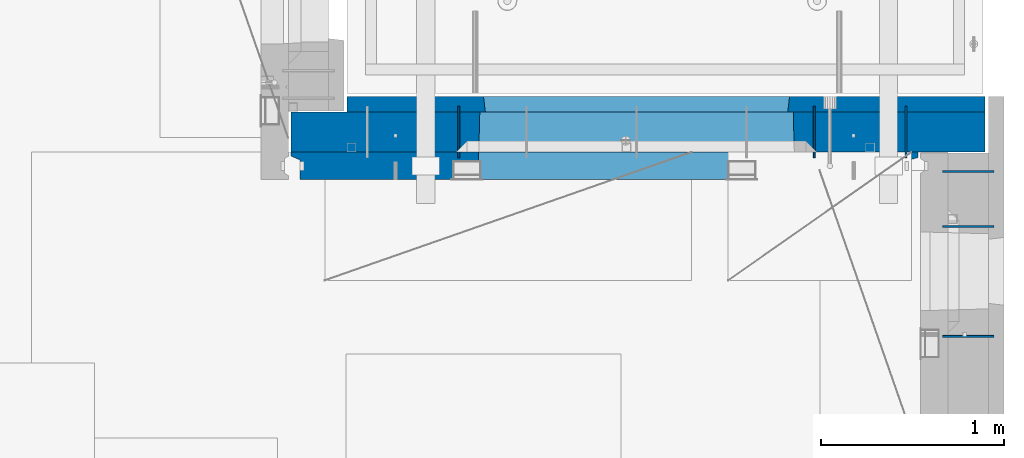
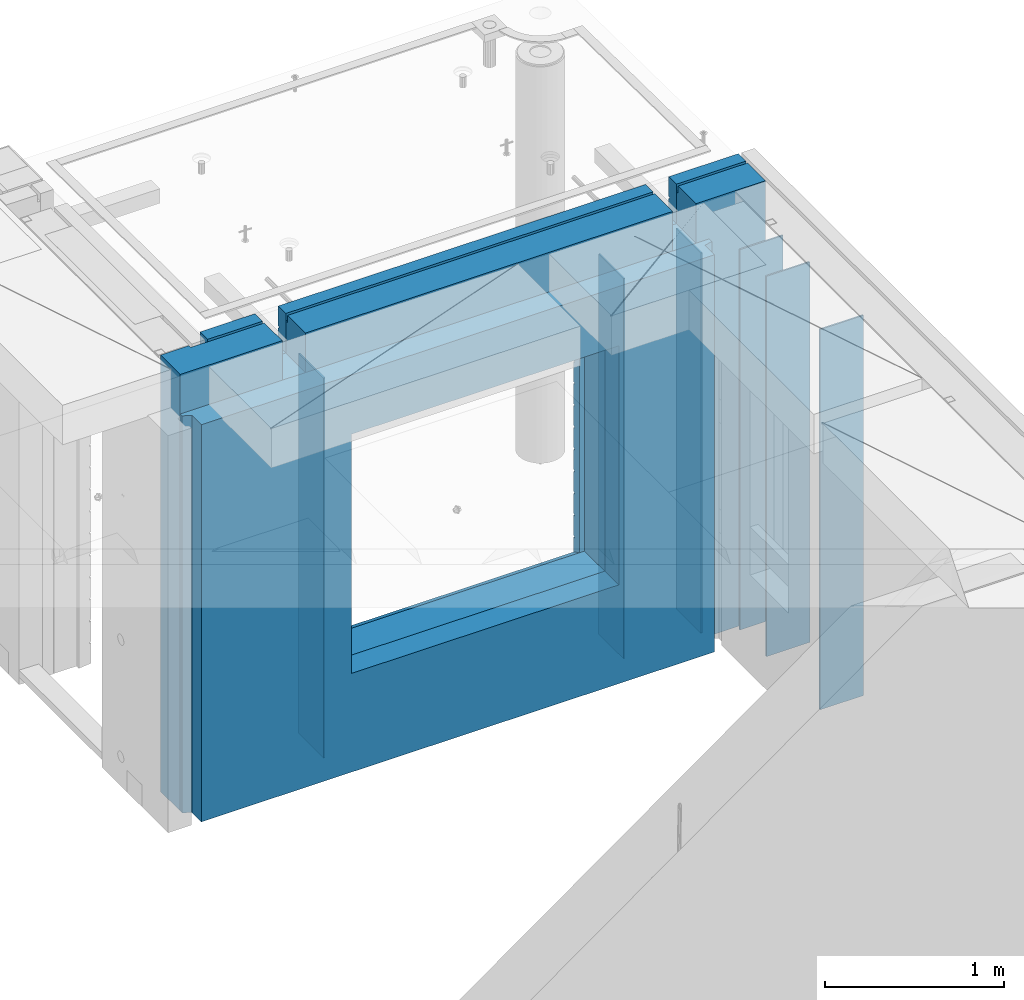
# One storey, part 231 of 334: 9 walls, 2 elements without a shape of their own.
"""IFC2X3 building model written with IfcOpenShell, lengths in millimetres."""

import ifcopenshell
import ifcopenshell.guid

model = None  # the IFC model being written
_history = None  # IfcOwnerHistory: only IFC2X3 demands one
_inside = {}  # id of a spatial element -> (the spatial element, [elements in it])
_under = {}  # id of a project, library or spatial element -> (it, [spatial elements below it])
_declared = {}  # id of a project -> (the project, [libraries it declares])
_typed = {}  # id of a type object -> (the type object, [elements of that type])
_made_of = {}  # id of a material, layer set ... -> (it, [elements and type objects made of it])


def new_model(schema):
    """Start an empty IFC model of exactly this schema.

    Asked for "IFC4X3", IfcOpenShell would pick the latest addendum, in which some entities
    have other attributes; the version numbers below select the first issue.
    IFC2X3 requires an IfcOwnerHistory on every rooted entity: one is made here for all.
    """
    global model, _history
    if schema == "IFC4X3":
        model = ifcopenshell.file(schema_version=(4, 3, 0, 0))
    else:
        model = ifcopenshell.file(schema=schema)
    _inside.clear()
    _under.clear()
    _declared.clear()
    _typed.clear()
    _made_of.clear()
    _history = None
    if model.schema == "IFC2X3":
        org = make("IfcOrganization", Name="unknown")
        user = make(
            "IfcPersonAndOrganization",
            ThePerson=make("IfcPerson", FamilyName="unknown"),
            TheOrganization=org,
        )
        app = make(
            "IfcApplication",
            ApplicationDeveloper=org,
            Version="unknown",
            ApplicationFullName="unknown",
            ApplicationIdentifier="unknown",
        )
        _history = make(
            "IfcOwnerHistory",
            OwningUser=user,
            OwningApplication=app,
            ChangeAction="ADDED",
            CreationDate=0,
        )
    return model


def make(cls, **values):
    """One entity of the class cls with the attributes given. An attribute that is None is left unset."""
    return model.create_entity(
        cls, **{name: value for name, value in values.items() if value is not None}
    )


def rooted(cls, **values):
    """An entity with a GlobalId (a new one), such as an element, a storey or a relation."""
    return make(cls, GlobalId=ifcopenshell.guid.new(), OwnerHistory=_history, **values)


def si_unit(unit_type, name, prefix=None):
    """IfcSIUnit, for example si_unit("LENGTHUNIT", "METRE", prefix="MILLI")."""
    return make("IfcSIUnit", UnitType=unit_type, Prefix=prefix, Name=name)


def assignment(units):
    """IfcUnitAssignment: the units of a project."""
    return None if units is None else make("IfcUnitAssignment", Units=units)


def point(xyz):
    """IfcCartesianPoint."""
    return None if xyz is None else make("IfcCartesianPoint", Coordinates=xyz)


def direction(xyz):
    """IfcDirection."""
    return None if xyz is None else make("IfcDirection", DirectionRatios=xyz)


def frame(location, z_axis=None, x_axis=None):
    """IfcAxis2Placement3D, a coordinate frame: its origin and axes. An axis left out is left unset."""
    return make(
        "IfcAxis2Placement3D",
        Location=point(location),
        Axis=direction(z_axis),
        RefDirection=direction(x_axis),
    )


def origin_with_axes():
    """The frame at (0, 0, 0) with the z axis (0, 0, 1) and the x axis (1, 0, 0) written out."""
    return frame((0.0, 0.0, 0.0), z_axis=(0.0, 0.0, 1.0), x_axis=(1.0, 0.0, 0.0))


def place(relative_to, where):
    """IfcLocalPlacement: puts the frame where relative to a parent placement (None: the world)."""
    return make(
        "IfcLocalPlacement", PlacementRelTo=relative_to, RelativePlacement=where
    )


def context(
    kind, dimensions, precision=None, world=None, true_north=None, identifier=None
):
    """IfcGeometricRepresentationContext, for example the 3D "Model" context."""
    return make(
        "IfcGeometricRepresentationContext",
        ContextIdentifier=identifier,
        ContextType=kind,
        CoordinateSpaceDimension=dimensions,
        Precision=precision,
        WorldCoordinateSystem=world,
        TrueNorth=true_north,
    )


def subcontext(parent, identifier, kind, view, scale=None):
    """IfcGeometricRepresentationSubContext, for example "Body" below "Model"."""
    return make(
        "IfcGeometricRepresentationSubContext",
        ContextIdentifier=identifier,
        ContextType=kind,
        ParentContext=parent,
        TargetScale=scale,
        TargetView=view,
    )


def project(units=None, contexts=None):
    """IfcProject with its units and contexts."""
    return rooted(
        "IfcProject",
        Name="project",
        RepresentationContexts=contexts,
        UnitsInContext=assignment(units),
    )


def spatial(cls, under=None, at=None, **own):
    """A site, building, storey or space (cls), placed at a placement, below another one or the project."""
    s = rooted(cls, ObjectPlacement=at, **own)
    if under is not None:
        _under.setdefault(under.id(), (under, []))[1].append(s)
    return s


def faces_of(points, faces, orient=None, outer=None):
    """IfcFace entities. A face is a list of loops; a loop is a list of indices into points, from 0.

    orient and outer hold one flag for each loop. By default every Orientation is true, the
    first loop of a face is its IfcFaceOuterBound and the others are IfcFaceBound.
    """
    made = []
    for i, loops in enumerate(faces):
        bounds = []
        for j, loop in enumerate(loops):
            is_outer = j == 0 if outer is None else outer[i][j]
            bounds.append(
                make(
                    "IfcFaceOuterBound" if is_outer else "IfcFaceBound",
                    Bound=make("IfcPolyLoop", Polygon=[points[k] for k in loop]),
                    Orientation=True if orient is None else orient[i][j],
                )
            )
        made.append(make("IfcFace", Bounds=bounds))
    return made


def faceted_brep(points, faces, orient=None, outer=None, voids=None):
    """IfcFacetedBrep: a solid bounded by flat faces; with voids (closed shells), ...WithVoids."""
    shared = [point(p) for p in points]
    hull = make("IfcClosedShell", CfsFaces=faces_of(shared, faces, orient, outer))
    if voids is None:
        return make("IfcFacetedBrep", Outer=hull)
    return make(
        "IfcFacetedBrepWithVoids",
        Outer=hull,
        Voids=[
            make(cls, CfsFaces=faces_of(shared, fs, o, b)) for cls, fs, o, b in voids
        ],
    )


def shape(context_of_items, identifier, shape_type, items):
    """IfcShapeRepresentation: the items that make up one representation, for example the "Body"."""
    return make(
        "IfcShapeRepresentation",
        ContextOfItems=context_of_items,
        RepresentationIdentifier=identifier,
        RepresentationType=shape_type,
        Items=items,
    )


def material(Name=None, Category=None):
    """IfcMaterial."""
    return make("IfcMaterial", Name=Name, Category=Category)


def made_of(thing, what):
    """Note that an element or type object is made of a material, layer set ...; save() writes the relation."""
    if what is not None:
        _made_of.setdefault(what.id(), (what, []))[1].append(thing)
    return thing


def type_object(cls, material=None, **own):
    """A type object (cls), such as IfcWallType, which elements share."""
    return made_of(rooted(cls, **own), material)


def element(
    cls,
    number,
    at=None,
    inside=None,
    cuts=None,
    type_object=None,
    material=None,
    context=None,
    identifier="Body",
    shape_type=None,
    held_by="IfcProductDefinitionShape",
    body=None,
    shapes=None,
    **own,
):
    """One element of the class cls, such as IfcWall. Its Tag is "e" and its number.

    at: its placement. inside: the storey or other place that contains it. cuts: it is an
    opening in that element (IfcRelVoidsElement). A single representation is given by context,
    identifier, shape_type and body (its items); several are given by shapes. held_by: the class
    of the entity that holds the representations. save() writes the other relations.
    """
    e = rooted(cls, Tag="e%d" % number, ObjectPlacement=at, **own)
    if body is not None:
        shapes = [shape(context, identifier, shape_type, body)]
    if shapes is not None:
        e.Representation = make(held_by, Representations=shapes)
    if inside is not None:
        _inside.setdefault(inside.id(), (inside, []))[1].append(e)
    if cuts is not None:
        rooted(
            "IfcRelVoidsElement", RelatingBuildingElement=cuts, RelatedOpeningElement=e
        )
    if type_object is not None:
        _typed.setdefault(type_object.id(), (type_object, []))[1].append(e)
    return made_of(e, material)


def aggregate(whole, parts):
    """IfcRelAggregates: a whole, such as a stair, and the parts it consists of."""
    return rooted("IfcRelAggregates", RelatingObject=whole, RelatedObjects=parts)


def save(model, path):
    """Write the relations noted so far, then the file.

    IfcRelAggregates (storeys below a building ...), IfcRelContainedInSpatialStructure (elements
    in a storey), IfcRelDefinesByType, IfcRelAssociatesMaterial and IfcRelDeclares: one each for
    every whole, place, type object, material and project.
    """
    for whole, parts in _under.values():
        aggregate(whole, parts)
    for where, things in _inside.values():
        rooted(
            "IfcRelContainedInSpatialStructure",
            RelatedElements=things,
            RelatingStructure=where,
        )
    for kind, things in _typed.values():
        rooted("IfcRelDefinesByType", RelatedObjects=things, RelatingType=kind)
    for what, things in _made_of.values():
        rooted("IfcRelAssociatesMaterial", RelatedObjects=things, RelatingMaterial=what)
    for by, libraries in _declared.values():
        rooted("IfcRelDeclares", RelatingContext=by, RelatedDefinitions=libraries)
    model.write(path)


model = new_model("IFC2X3")

# Units and contexts
model_context = context("Model", 3, precision=1e-05, world=origin_with_axes())
body_context = subcontext(model_context, "Body", "Model", "MODEL_VIEW")
ifc_project = project(units=[si_unit("LENGTHUNIT", "METRE", prefix="MILLI"), si_unit("AREAUNIT", "SQUARE_METRE"), si_unit("VOLUMEUNIT", "CUBIC_METRE"), si_unit("MASSUNIT", "GRAM", prefix="KILO"), si_unit("TIMEUNIT", "SECOND"), si_unit("PLANEANGLEUNIT", "RADIAN"), si_unit("SOLIDANGLEUNIT", "STERADIAN"), si_unit("THERMODYNAMICTEMPERATUREUNIT", "DEGREE_CELSIUS"), si_unit("LUMINOUSINTENSITYUNIT", "LUMEN")], contexts=[model_context])

# Site, building, storey
site_placement = place(None, origin_with_axes())
site = spatial("IfcSite", under=ifc_project, at=site_placement, CompositionType="ELEMENT")
building_placement = place(site_placement, origin_with_axes())
building = spatial("IfcBuilding", under=site, at=building_placement, CompositionType="ELEMENT")
storey_placement = place(building_placement, origin_with_axes())
storey = spatial("IfcBuildingStorey", under=building, at=storey_placement, Name="3", CompositionType="ELEMENT", Elevation=0.0)

# Assembly, walls
assembly_1_placement = place(storey_placement, origin_with_axes())
assembly_1 = element("IfcElementAssembly", 1, at=assembly_1_placement, inside=storey, AssemblyPlace="NOTDEFINED", PredefinedType="REINFORCEMENT_UNIT")
ifc_material_1 = material(Name="Undefined")
wall_type_1 = type_object("IfcWallType", PredefinedType="NOTDEFINED")
wall_1_placement = place(assembly_1_placement, frame((34830.0, 20549.9951872276, 89115.0), z_axis=(0.0, 0.0, 1.0), x_axis=(0.0, 1.0, 0.0)))
wall_1 = element("IfcWall", 2, at=wall_1_placement, type_object=wall_type_1, material=ifc_material_1, Name="(PD)", context=body_context, shape_type="Brep", body=[
    faceted_brep([(0.0, 5.0, -1300.0), (0.0, 5.0, 1300.0), (280.0, 5.0, 1300.0), (280.0, 5.0, -1300.0), (0.0, -5.0, 1300.0), (280.0, -5.0, 1300.0), (0.0, -5.0, -1300.0), (280.0, -5.0, -1300.0)], [[[0, 1, 2, 3]], [[1, 4, 5, 2]], [[4, 6, 7, 5]], [[6, 0, 3, 7]], [[5, 7, 3, 2]], [[6, 4, 1, 0]]]),
])
wall_2_placement = place(assembly_1_placement, frame((34330.0, 20549.9951872276, 89115.0), z_axis=(0.0, 0.0, 1.0), x_axis=(0.0, 1.0, 0.0)))
wall_2 = element("IfcWall", 3, at=wall_2_placement, type_object=wall_type_1, material=ifc_material_1, Name="(PD)", context=body_context, shape_type="Brep", body=[
    faceted_brep([(0.0, 5.0, -1300.0), (0.0, 5.0, 1300.0), (280.0, 5.0, 1300.0), (280.0, 5.0, -1300.0), (0.0, -5.0, 1300.0), (280.0, -5.0, 1300.0), (0.0, -5.0, -1300.0), (280.0, -5.0, -1300.0)], [[[0, 1, 2, 3]], [[1, 4, 5, 2]], [[4, 6, 7, 5]], [[6, 0, 3, 7]], [[5, 7, 3, 2]], [[6, 4, 1, 0]]]),
])
wall_3_placement = place(assembly_1_placement, frame((32390.0, 20549.9951872276, 89115.0), z_axis=(0.0, 0.0, 1.0), x_axis=(0.0, 1.0, 0.0)))
wall_3 = element("IfcWall", 4, at=wall_3_placement, type_object=wall_type_1, material=ifc_material_1, Name="(PD)", context=body_context, shape_type="Brep", body=[
    faceted_brep([(0.0, 5.0, -1300.0), (0.0, 5.0, 1300.0), (280.0, 5.0, 1300.0), (280.0, 5.0, -1300.0), (0.0, -5.0, 1300.0), (280.0, -5.0, 1300.0), (0.0, -5.0, -1300.0), (280.0, -5.0, -1300.0)], [[[0, 1, 2, 3]], [[1, 4, 5, 2]], [[4, 6, 7, 5]], [[6, 0, 3, 7]], [[5, 7, 3, 2]], [[6, 4, 1, 0]]]),
])

assembly_2_placement = place(storey_placement, origin_with_axes())
assembly_2 = element("IfcElementAssembly", 5, at=assembly_2_placement, inside=storey, AssemblyPlace="NOTDEFINED", PredefinedType="REINFORCEMENT_UNIT")
wall_4_placement = place(assembly_2_placement, frame((35030.0, 20175.0002441406, 89115.0), z_axis=(0.0, 0.0, 1.0), x_axis=(1.0, 0.0, 0.0)))
wall_4 = element("IfcWall", 6, at=wall_4_placement, type_object=wall_type_1, material=ifc_material_1, Name="(PD)", context=body_context, shape_type="Brep", body=[
    faceted_brep([(0.0, 5.0, -1300.0), (0.0, 5.0, 1300.0), (280.0, 5.0, 1300.0), (280.0, 5.0, -1300.0), (0.0, -5.0, 1300.0), (280.0, -5.0, 1300.0), (0.0, -5.0, -1300.0), (280.0, -5.0, -1300.0)], [[[0, 1, 2, 3]], [[1, 4, 5, 2]], [[4, 6, 7, 5]], [[6, 0, 3, 7]], [[5, 7, 3, 2]], [[6, 4, 1, 0]]]),
])
wall_5_placement = place(assembly_2_placement, frame((35030.0, 20475.0002441406, 89115.0), z_axis=(0.0, 0.0, 1.0), x_axis=(1.0, 0.0, 0.0)))
wall_5 = element("IfcWall", 7, at=wall_5_placement, type_object=wall_type_1, material=ifc_material_1, Name="(PD)", context=body_context, shape_type="Brep", body=[
    faceted_brep([(0.0, 5.0, -1300.0), (0.0, 5.0, 1300.0), (280.0, 5.0, 1300.0), (280.0, 5.0, -1300.0), (0.0, -5.0, 1300.0), (280.0, -5.0, 1300.0), (0.0, -5.0, -1300.0), (280.0, -5.0, -1300.0)], [[[0, 1, 2, 3]], [[1, 4, 5, 2]], [[4, 6, 7, 5]], [[6, 0, 3, 7]], [[5, 7, 3, 2]], [[6, 4, 1, 0]]]),
])
wall_6_placement = place(assembly_2_placement, frame((35030.0, 19575.0002441406, 89115.0), z_axis=(0.0, 0.0, 1.0), x_axis=(1.0, 0.0, 0.0)))
wall_6 = element("IfcWall", 8, at=wall_6_placement, type_object=wall_type_1, material=ifc_material_1, Name="(PD)", context=body_context, shape_type="Brep", body=[
    faceted_brep([(0.0, 5.0, -1300.0), (0.0, 5.0, 1300.0), (280.0, 5.0, 1300.0), (280.0, 5.0, -1300.0), (0.0, -5.0, 1300.0), (280.0, -5.0, 1300.0), (0.0, -5.0, -1300.0), (280.0, -5.0, -1300.0)], [[[0, 1, 2, 3]], [[1, 4, 5, 2]], [[4, 6, 7, 5]], [[6, 0, 3, 7]], [[5, 7, 3, 2]], [[6, 4, 1, 0]]]),
])
aggregate(assembly_2, [wall_4, wall_5, wall_6])

# Wall
ifc_material_2 = material(Name="COS5gt")
wall_type_2 = type_object("IfcWallType", PredefinedType="NOTDEFINED")
wall_7_placement = place(assembly_1_placement, frame((31475.0, 20689.9951872276, 89247.5), z_axis=(0.0, 0.0, 1.0), x_axis=(1.0, 0.0, 0.0)))
wall_7 = element("IfcWall", 9, at=wall_7_placement, type_object=wall_type_2, material=ifc_material_2, context=body_context, shape_type="Brep", body=[
    faceted_brep([(810.0, 110.0, 1442.5), (810.0, 90.0, 1442.5), (3185.0, 90.0, 1442.5), (3185.0, 110.0, 1442.5), (810.0, 90.0, 1492.5), (810.0, -110.0, 1492.5), (3185.0, -110.0, 1492.5), (3185.0, 90.0, 1492.5), (184.0, 90.0, 1442.5), (184.0, 90.0, 1492.5), (660.0, 90.0, 1492.5), (660.0, 90.0, 1442.5), (184.0, 110.0, 1492.5), (184.0, 110.0, 1442.5), (0.0, 110.0, 1492.5), (0.0, -110.0, 1492.5), (660.0, -110.0, 1492.5), (0.0, -110.0, -1492.5), (0.0, 110.0, -1492.5), (3785.0, 90.0, -1492.5), (184.0, 90.0, -1492.5), (184.0, 90.0, -1442.5), (3785.0, 90.0, -1442.5), (3785.0, -110.0, -1492.5), (184.0, 110.0, -1492.5), (184.0, 110.0, -1442.5), (3785.0, 110.0, -1442.5), (3785.0, 110.0, 1442.5), (3785.0, 90.0, 1442.5), (3785.0, 90.0, 1492.5), (3785.0, -110.0, 1492.5), (3335.0, 90.0, 1492.5), (3335.0, -110.0, 1492.5), (3185.0, -110.000000000004, 1222.5), (810.0, -110.0, 1222.5), (660.0, -110.0, 1222.5), (3335.0, -110.000000000004, 1222.5), (1024.05429979644, -110.000000000004, -813.445945945947), (1024.05429979644, -110.000000000004, 813.445945945947), (2745.94619168834, -110.000000000004, 813.445945945947), (2745.94619168834, -110.000000000004, -813.445945945947), (1030.00024574239, 110.0, -802.5), (1030.00024574239, 110.0, 807.5), (1030.00024574239, 110.0, -807.5), (2740.00024574239, 110.0, -807.5), (2710.00024574239, 110.0, -807.5), (1060.00024574239, 110.0, -807.5), (2740.00024574239, 110.0, 807.5), (2740.00024574239, 110.0, -802.5), (660.0, 110.0, 1442.5), (660.0, 109.999999999996, 1222.5), (810.0, 109.999999999996, 1222.5), (3185.0, 109.999999999996, 1222.5), (3335.0, 109.999999999996, 1222.5), (3335.0, 110.0, 1442.5), (3335.0, 90.0, 1442.5)], [[[0, 1, 2, 3]], [[4, 5, 6, 7]], [[8, 9, 10, 11]], [[12, 9, 8, 13]], [[9, 12, 14, 15, 16, 10]], [[17, 15, 14, 18]], [[19, 20, 21, 22]], [[23, 17, 18, 24, 20, 19]], [[25, 21, 20, 24]], [[26, 22, 21, 25]], [[27, 28, 29, 30, 23, 19, 22, 26]], [[30, 29, 31, 32]], [[33, 6, 5, 34, 35, 16, 15, 17, 23, 30, 32, 36], [37, 38, 39, 40]], [[41, 42, 38, 37, 43]], [[40, 44, 45, 46, 43, 37]], [[39, 47, 48, 44, 40]], [[38, 42, 47, 39]], [[27, 26, 25, 24, 18, 14, 12, 13, 49, 50, 51, 0, 3, 52, 53, 54], [41, 43, 46, 45, 44, 48, 47, 42]], [[28, 27, 54, 55]], [[29, 28, 55, 31]], [[54, 53, 36, 32, 31, 55]], [[52, 33, 36, 53]], [[3, 2, 7, 6, 33, 52]], [[1, 4, 7, 2]], [[0, 51, 34, 5, 4, 1]], [[50, 35, 34, 51]], [[49, 11, 10, 16, 35, 50]], [[13, 8, 11, 49]]]),
])

ifc_material_3 = material(Name="CONCRETE/C30/37")
wall_type_3 = type_object("IfcWallType", PredefinedType="NOTDEFINED")
wall_8_placement = place(assembly_1_placement, frame((31780.0, 20842.4951872276, 89247.5), z_axis=(0.0, 0.0, 1.0), x_axis=(1.0, 0.0, 0.0)))
wall_8 = element("IfcWall", 10, at=wall_8_placement, type_object=wall_type_3, material=ifc_material_3, context=body_context, shape_type="Brep", body=[
    faceted_brep([(3480.0, -42.5, 1492.5), (3480.0, 42.5, 1492.5), (3030.0, 42.5, 1492.5), (3030.0, -42.5, 1492.5), (3480.0, 42.4999992431694, 1356.99999988925), (3030.0, 42.4999993410347, 1356.99999988925), (3480.0, 32.4999991127006, 1355.00000040044), (3480.0, 32.4999992507037, 1344.99999999926), (3030.0, 32.4999992507037, 1344.99999999926), (3030.0, 32.4999991127006, 1355.00000040044), (3480.0, 42.4999996036895, 1342.99999994476), (3030.0, 42.4999996549377, 1342.99999994476), (3480.0, 42.4999993831152, 892.999999944761), (0.0, 42.5, 892.999999944761), (0.0, 32.4999992507037, 894.999999999258), (3480.0, 32.4999992507037, 894.999999999258), (0.0, 32.4999991127006, 905.00000040044), (3480.0, 32.4999991127006, 905.00000040044), (3480.0, 42.4999992431694, 906.999999889245), (0.0, 42.5, 906.999999889245), (0.0, 42.5, 1042.99999994476), (3480.0, 42.4999994189675, 1042.99999994476), (0.0, 32.4999992507037, 1044.99999999926), (3480.0, 32.4999992507037, 1044.99999999926), (0.0, 32.4999991127006, 1055.00000040044), (3480.0, 32.4999991127006, 1055.00000040044), (3480.0, 42.4999992431694, 1056.99999988925), (0.0, 42.5, 1056.99999988925), (0.0, 42.5, 1192.99999994476), (3480.0, 42.4999994795144, 1192.99999994476), (0.0, 32.4999992507037, 1194.99999999926), (3480.0, 32.4999992507037, 1194.99999999926), (0.0, 32.4999991127006, 1205.00000040044), (3480.0, 32.4999991127006, 1205.00000040044), (3480.0, 42.4999992431694, 1206.99999988925), (0.0, 42.5, 1206.99999988925), (-3.63797880709171e-12, 32.4999992507037, 1344.99999999926), (-3.63797880709171e-12, 32.4999991127006, 1355.00000040044), (355.0, 32.4999991127006, 1355.00000040044), (355.0, 32.4999992507037, 1344.99999999926), (0.0, 42.5, 1342.99999994476), (355.0, 42.4999999595711, 1342.99999994476), (505.0, 32.4999992507037, 1344.99999999926), (505.0, 32.4999991127006, 1355.00000040044), (2880.0, 32.4999991127006, 1355.00000040044), (2880.0, 32.4999992507037, 1344.99999999926), (505.0, 42.4999999424908, 1342.99999994476), (2880.0, 42.4999996720217, 1342.99999994476), (355.0, 42.4999998715975, 1222.5), (505.0, 42.4999998467429, 1222.5), (2880.0, 42.4999994331811, 1222.5), (3030.0, 42.4999994081736, 1222.5), (355.0, -42.5, 1222.5), (505.0, -42.5, 1222.5), (505.0, 42.5, 1492.5), (505.0, 42.4999998901731, 1356.99999988925), (505.0, -42.5, 1492.5), (2880.0, -42.5, 1492.5), (2880.0, 42.5, 1492.5), (2880.0, 42.4999993736565, 1356.99999988925), (2880.0, -42.5000000000036, 1222.5), (3030.0, -42.5000000000036, 1222.5), (3480.0, -42.5, -1492.5), (3480.0, 42.5, -1492.5), (3480.0, 42.5, -1357.00000005524), (3480.0, 32.4999992507037, -1355.00000000074), (3480.0, 32.4999991127006, -1344.99999959956), (3480.0, 42.4999992431694, -1343.00000011075), (3480.0, 42.4999992794692, -1207.00000005524), (3480.0, 32.4999992507037, -1205.00000000074), (3480.0, 32.4999991127006, -1194.99999959956), (3480.0, 42.4999992431694, -1193.00000011075), (3480.0, 42.4999992814955, -1057.00000005524), (3480.0, 32.4999992507037, -1055.00000000074), (3480.0, 32.4999991127006, -1044.99999959956), (3480.0, 42.4999992431694, -1043.00000011075), (3480.0, 42.4999992837656, -907.000000055239), (3480.0, 32.4999992507037, -905.000000000742), (3480.0, 32.4999991127006, -894.99999959956), (3480.0, 42.4999992431694, -893.000000110755), (3480.0, 42.4999992863159, -757.000000055239), (3480.0, 32.4999992507037, -755.000000000742), (3480.0, 32.4999991127006, -744.99999959956), (3480.0, 42.4999992431694, -743.000000110755), (3480.0, 42.4999992892117, -607.000000055239), (3480.0, 32.4999992507037, -605.000000000742), (3480.0, 32.4999991127006, -594.99999959956), (3480.0, 42.4999992431694, -593.000000110755), (3480.0, 42.4999992925223, -457.000000055239), (3480.0, 32.4999992507037, -455.000000000742), (3480.0, 32.4999991127006, -444.99999959956), (3480.0, 42.4999992431694, -443.000000110755), (3480.0, 42.4999992963494, -307.000000055239), (3480.0, 32.4999992507037, -305.000000000742), (3480.0, 32.4999991127006, -294.99999959956), (3480.0, 42.4999992431694, -293.000000110755), (3480.0, 42.4999993008169, -157.000000055239), (3480.0, 32.4999992507037, -155.000000000742), (3480.0, 32.4999991127006, -144.99999959956), (3480.0, 42.4999992431694, -143.000000110755), (3480.0, 42.4999993061028, -7.00000005523907), (3480.0, 32.4999992507037, -5.00000000074215), (3480.0, 32.4999991127006, 5.0000004004396), (3480.0, 42.4999992431694, 6.99999988924537), (3480.0, 42.4999993124584, 142.999999944761), (3480.0, 32.4999992507037, 144.999999999258), (3480.0, 32.4999991127006, 155.00000040044), (3480.0, 42.4999992431694, 156.999999889245), (3480.0, 42.49999932024, 292.999999944761), (3480.0, 32.4999992507037, 294.999999999258), (3480.0, 32.4999991127006, 305.00000040044), (3480.0, 42.4999992431694, 306.999999889245), (3480.0, 42.4999993299934, 442.999999944761), (3480.0, 32.4999992507037, 444.999999999258), (3480.0, 32.4999991127006, 455.00000040044), (3480.0, 42.4999992431694, 456.999999889245), (3480.0, 42.4999993425699, 592.999999944761), (3480.0, 32.4999992507037, 594.999999999258), (3480.0, 32.4999991127006, 605.00000040044), (3480.0, 42.4999992431694, 606.999999889245), (3480.0, 42.4999993594065, 742.999999944761), (3480.0, 32.4999992507037, 744.999999999258), (3480.0, 32.4999991127006, 755.00000040044), (3480.0, 42.4999992431694, 756.999999889245), (0.0, -42.5, -1492.5), (0.0, 42.5, -1492.5), (0.0, 42.5, -1357.00000005524), (0.0, 32.4999992507037, -1355.00000000074), (0.0, 32.4999991127006, -1344.99999959956), (0.0, 42.5, -1343.00000011075), (0.0, 42.5, -1207.00000005524), (0.0, 32.4999992507037, -1205.00000000074), (0.0, 32.4999991127006, -1194.99999959956), (0.0, 42.5, -1193.00000011075), (0.0, 42.5, -1057.00000005524), (0.0, 32.4999992507037, -1055.00000000074), (0.0, 32.4999991127006, -1044.99999959956), (0.0, 42.5, -1043.00000011075), (0.0, 42.5, -907.000000055239), (0.0, 32.4999992507037, -905.000000000742), (0.0, 32.4999991127006, -894.99999959956), (0.0, 42.5, -893.000000110755), (0.0, 32.4999991127006, 755.00000040044), (0.0, 42.5, 756.999999889245), (745.000245742391, 42.4999998379753, 756.999999889245), (746.176716435013, 32.4999991127006, 755.00000040044), (0.0, 32.4999992507037, 744.999999999258), (746.17671641878, 32.4999992507037, 744.999999999258), (0.0, 42.5, 742.999999944761), (745.000245742391, 42.4999998628628, 742.999999944761), (0.0, 42.5, 606.999999889245), (745.000245742391, 42.4999998379753, 606.999999889245), (3.63797880709171e-12, 32.4999991127006, 605.00000040044), (746.176716435013, 32.4999991127006, 605.00000040044), (3.63797880709171e-12, 32.4999992507037, 594.999999999258), (746.176716418777, 32.4999992507037, 594.999999999258), (0.0, 42.5, 592.999999944761), (745.000245742391, 42.4999998592575, 592.999999944761), (0.0, 42.5, 456.999999889245), (745.000245742391, 42.4999998379753, 456.999999889245), (0.0, 32.4999991127006, 455.00000040044), (746.176716435013, 32.4999991127006, 455.00000040044), (0.0, 32.4999992507037, 444.999999999258), (746.17671641878, 32.4999992507037, 444.999999999258), (0.0, 42.5, 442.999999944761), (745.000245742391, 42.4999998565654, 442.999999944761), (0.0, 42.5, 306.999999889245), (745.000245742391, 42.4999998379753, 306.999999889245), (-3.63797880709171e-12, 32.4999991127006, 305.00000040044), (746.176716435013, 32.4999991127006, 305.00000040044), (-3.63797880709171e-12, 32.4999992507037, 294.999999999258), (746.176716418777, 32.4999992507037, 294.999999999258), (0.0, 42.5, 292.999999944761), (745.000245742391, 42.4999998544772, 292.999999944761), (0.0, 42.5, 156.999999889245), (745.000245742391, 42.4999998379753, 156.999999889245), (-3.63797880709171e-12, 32.4999991127006, 155.00000040044), (746.176716435013, 32.4999991127006, 155.00000040044), (-3.63797880709171e-12, 32.4999992507037, 144.999999999258), (746.176716418777, 32.4999992507037, 144.999999999258), (0.0, 42.5, 142.999999944761), (745.000245742391, 42.499999852811, 142.999999944761), (0.0, 42.5, 6.99999988924537), (745.000245742391, 42.4999998379753, 6.99999988924537), (0.0, 32.4999991127006, 5.0000004004396), (746.176716435013, 32.4999991127006, 5.0000004004396), (0.0, 32.4999992507037, -5.00000000074215), (746.17671641878, 32.4999992507037, -5.00000000074215), (0.0, 42.5, -7.00000005523907), (745.000245742391, 42.4999998514504, -7.00000005523907), (0.0, 42.5, -143.000000110755), (745.000245742391, 42.4999998379753, -143.000000110755), (3.63797880709171e-12, 32.4999991127006, -144.99999959956), (746.176716435013, 32.4999991127006, -144.99999959956), (3.63797880709171e-12, 32.4999992507037, -155.000000000742), (746.176716418777, 32.4999992507037, -155.000000000742), (0.0, 42.5, -157.000000055239), (745.000245742391, 42.499999850319, -157.000000055239), (0.0, 42.5, -293.000000110755), (745.000245742391, 42.4999998379753, -293.000000110755), (0.0, 32.4999991127006, -294.99999959956), (746.176716435013, 32.4999991127006, -294.99999959956), (0.0, 32.4999992507037, -305.000000000742), (746.17671641878, 32.4999992507037, -305.000000000742), (0.0, 42.5, -307.000000055239), (745.000245742391, 42.4999998493622, -307.000000055239), (0.0, 42.5, -443.000000110755), (745.000245742391, 42.4999998379753, -443.000000110755), (0.0, 32.4999991127006, -444.99999959956), (746.176716435013, 32.4999991127006, -444.99999959956), (0.0, 32.4999992507037, -455.000000000742), (746.17671641878, 32.4999992507037, -455.000000000742), (0.0, 42.5, -457.000000055239), (745.000245742391, 42.4999998485437, -457.000000055239), (0.0, 42.5, -593.000000110755), (745.000245742391, 42.4999998379753, -593.000000110755), (3.63797880709171e-12, 32.4999991127006, -594.99999959956), (746.176716435013, 32.4999991127006, -594.99999959956), (3.63797880709171e-12, 32.4999992507037, -605.000000000742), (746.176716418777, 32.4999992507037, -605.000000000742), (0.0, 42.5, -607.000000055239), (745.000245742391, 42.4999998478343, -607.000000055239), (0.0, 42.5, -743.000000110755), (745.000245742391, 42.4999998379753, -743.000000110755), (0.0, 32.4999991127006, -744.99999959956), (746.176716435013, 32.4999991127006, -744.99999959956), (0.0, 32.4999992507037, -755.000000000742), (746.17671641878, 32.4999992507037, -755.000000000742), (0.0, 42.5, -757.000000055239), (745.000245742391, 42.4999998472158, -757.000000055239), (745.000245742391, 42.5, -857.5), (755.000245742391, -42.5, -807.5), (2405.00024574239, -42.5, -807.5), (2415.00024574239, 42.5, -857.5), (2415.00024574239, 42.4999995047292, -757.000000055239), (2413.823775066, 32.4999992507037, -755.000000000742), (2413.82377504977, 32.4999991127006, -744.99999959956), (2415.00024574239, 42.499999474785, -743.000000110755), (2415.00024574239, 42.4999995067374, -607.000000055239), (2413.823775066, 32.4999992507037, -605.000000000742), (2413.82377504977, 32.4999991127006, -594.99999959956), (2415.00024574239, 42.499999474785, -593.000000110755), (2415.00024574239, 42.4999995090366, -457.000000055239), (2413.823775066, 32.4999992507037, -455.000000000742), (2413.82377504977, 32.4999991127006, -444.99999959956), (2415.00024574239, 42.499999474785, -443.000000110755), (2415.00024574239, 42.4999995116923, -307.000000055239), (2413.823775066, 32.4999992507037, -305.000000000742), (2413.82377504977, 32.4999991127006, -294.99999959956), (2415.00024574239, 42.499999474785, -293.000000110755), (2415.00024574239, 42.4999995147919, -157.000000055239), (2413.823775066, 32.4999992507037, -155.000000000742), (2413.82377504977, 32.4999991127006, -144.99999959956), (2415.00024574239, 42.499999474785, -143.000000110755), (2415.00024574239, 42.4999995184589, -7.00000005523907), (2413.823775066, 32.4999992507037, -5.00000000074215), (2413.82377504977, 32.4999991127006, 5.0000004004396), (2415.00024574239, 42.499999474785, 6.99999988924537), (2415.00024574239, 42.4999995228682, 142.999999944761), (2413.823775066, 32.4999992507037, 144.999999999258), (2413.82377504977, 32.4999991127006, 155.00000040044), (2415.00024574239, 42.499999474785, 156.999999889245), (2415.00024574239, 42.4999995282706, 292.999999944761), (2413.823775066, 32.4999992507037, 294.999999999258), (2413.82377504977, 32.4999991127006, 305.00000040044), (2415.00024574239, 42.499999474785, 306.999999889245), (2415.00024574239, 42.4999995350372, 442.999999944761), (2413.823775066, 32.4999992507037, 444.999999999258), (2413.82377504977, 32.4999991127006, 455.00000040044), (2415.00024574239, 42.499999474785, 456.999999889245), (2415.00024574239, 42.4999995437647, 592.999999944761), (2413.823775066, 32.4999992507037, 594.999999999258), (2413.82377504977, 32.4999991127006, 605.00000040044), (2415.00024574239, 42.499999474785, 606.999999889245), (2415.00024574239, 42.4999995554499, 742.999999944761), (2413.823775066, 32.4999992507037, 744.999999999258), (2413.82377504977, 32.4999991127006, 755.00000040044), (2415.00024574239, 42.499999474785, 756.999999889245), (755.000245742391, 42.5, 782.5), (745.000245742391, 42.5, 782.5), (2415.00024574239, 42.5, 782.5), (2405.00024574239, 42.5, 782.5), (755.000245742391, -42.5, 782.5), (755.000245742391, -42.5, 787.5), (2405.00024574239, -42.5, 787.5), (2405.00024574239, -42.5, 782.5), (355.0, -42.5, 1492.5), (0.0, -42.5, 1492.5), (0.0, 42.5, 1492.5), (355.0, 42.5, 1492.5), (0.0, 42.5, 1356.99999988925), (355.0, 42.4999999227948, 1356.99999988925)], [[[0, 1, 2, 3]], [[1, 4, 5, 2]], [[6, 7, 8, 9]], [[7, 10, 11, 8]], [[12, 13, 14, 15]], [[15, 14, 16, 17]], [[18, 17, 16, 19]], [[18, 19, 20, 21]], [[21, 20, 22, 23]], [[23, 22, 24, 25]], [[26, 25, 24, 27]], [[26, 27, 28, 29]], [[29, 28, 30, 31]], [[31, 30, 32, 33]], [[34, 33, 32, 35]], [[36, 37, 38, 39]], [[40, 36, 39, 41]], [[42, 43, 44, 45]], [[46, 42, 45, 47]], [[10, 34, 35, 40, 41, 48, 49, 46, 47, 50, 51, 11]], [[48, 52, 53, 49]], [[54, 55, 43, 42, 46, 49, 53, 56]], [[54, 56, 57, 58]], [[55, 54, 58, 59]], [[43, 55, 59, 44]], [[58, 57, 60, 50, 47, 45, 44, 59]], [[50, 60, 61, 51]], [[2, 5, 9, 8, 11, 51, 61, 3]], [[4, 6, 9, 5]], [[1, 0, 62, 63, 64, 65, 66, 67, 68, 69, 70, 71, 72, 73, 74, 75, 76, 77, 78, 79, 80, 81, 82, 83, 84, 85, 86, 87, 88, 89, 90, 91, 92, 93, 94, 95, 96, 97, 98, 99, 100, 101, 102, 103, 104, 105, 106, 107, 108, 109, 110, 111, 112, 113, 114, 115, 116, 117, 118, 119, 120, 121, 122, 123, 12, 15, 17, 18, 21, 23, 25, 26, 29, 31, 33, 34, 10, 7, 6, 4]], [[124, 125, 63, 62]], [[63, 125, 126, 64]], [[64, 126, 127, 65]], [[65, 127, 128, 66]], [[67, 66, 128, 129]], [[67, 129, 130, 68]], [[68, 130, 131, 69]], [[69, 131, 132, 70]], [[71, 70, 132, 133]], [[71, 133, 134, 72]], [[72, 134, 135, 73]], [[73, 135, 136, 74]], [[75, 74, 136, 137]], [[75, 137, 138, 76]], [[76, 138, 139, 77]], [[77, 139, 140, 78]], [[79, 78, 140, 141]], [[142, 143, 144, 145]], [[146, 142, 145, 147]], [[148, 146, 147, 149]], [[150, 148, 149, 151]], [[152, 150, 151, 153]], [[154, 152, 153, 155]], [[156, 154, 155, 157]], [[158, 156, 157, 159]], [[160, 158, 159, 161]], [[162, 160, 161, 163]], [[164, 162, 163, 165]], [[166, 164, 165, 167]], [[168, 166, 167, 169]], [[170, 168, 169, 171]], [[172, 170, 171, 173]], [[174, 172, 173, 175]], [[176, 174, 175, 177]], [[178, 176, 177, 179]], [[180, 178, 179, 181]], [[182, 180, 181, 183]], [[184, 182, 183, 185]], [[186, 184, 185, 187]], [[188, 186, 187, 189]], [[190, 188, 189, 191]], [[192, 190, 191, 193]], [[194, 192, 193, 195]], [[196, 194, 195, 197]], [[198, 196, 197, 199]], [[200, 198, 199, 201]], [[202, 200, 201, 203]], [[204, 202, 203, 205]], [[206, 204, 205, 207]], [[208, 206, 207, 209]], [[210, 208, 209, 211]], [[212, 210, 211, 213]], [[214, 212, 213, 215]], [[216, 214, 215, 217]], [[218, 216, 217, 219]], [[220, 218, 219, 221]], [[222, 220, 221, 223]], [[224, 222, 223, 225]], [[226, 224, 225, 227]], [[228, 226, 227, 229]], [[230, 231, 232, 233]], [[80, 79, 141, 228, 229, 230, 233, 234]], [[81, 80, 234, 235]], [[82, 81, 235, 236]], [[83, 82, 236, 237]], [[84, 83, 237, 238]], [[85, 84, 238, 239]], [[86, 85, 239, 240]], [[87, 86, 240, 241]], [[88, 87, 241, 242]], [[89, 88, 242, 243]], [[90, 89, 243, 244]], [[91, 90, 244, 245]], [[92, 91, 245, 246]], [[93, 92, 246, 247]], [[94, 93, 247, 248]], [[95, 94, 248, 249]], [[96, 95, 249, 250]], [[97, 96, 250, 251]], [[98, 97, 251, 252]], [[99, 98, 252, 253]], [[100, 99, 253, 254]], [[101, 100, 254, 255]], [[102, 101, 255, 256]], [[103, 102, 256, 257]], [[104, 103, 257, 258]], [[105, 104, 258, 259]], [[106, 105, 259, 260]], [[107, 106, 260, 261]], [[108, 107, 261, 262]], [[109, 108, 262, 263]], [[110, 109, 263, 264]], [[111, 110, 264, 265]], [[112, 111, 265, 266]], [[113, 112, 266, 267]], [[114, 113, 267, 268]], [[115, 114, 268, 269]], [[116, 115, 269, 270]], [[117, 116, 270, 271]], [[118, 117, 271, 272]], [[119, 118, 272, 273]], [[120, 119, 273, 274]], [[121, 120, 274, 275]], [[122, 121, 275, 276]], [[123, 122, 276, 277]], [[278, 279, 144, 143, 13, 12, 123, 277, 280, 281]], [[282, 231, 230, 229, 227, 225, 223, 221, 219, 217, 215, 213, 211, 209, 207, 205, 203, 201, 199, 197, 195, 193, 191, 189, 187, 185, 183, 181, 179, 177, 175, 173, 171, 169, 167, 165, 163, 161, 159, 157, 155, 153, 151, 149, 147, 145, 144, 279, 283]], [[278, 281, 280, 284, 283, 279]], [[277, 276, 275, 274, 273, 272, 271, 270, 269, 268, 267, 266, 265, 264, 263, 262, 261, 260, 259, 258, 257, 256, 255, 254, 253, 252, 251, 250, 249, 248, 247, 246, 245, 244, 243, 242, 241, 240, 239, 238, 237, 236, 235, 234, 233, 232, 285, 284, 280]], [[60, 57, 56, 53, 52, 286, 287, 124, 62, 0, 3, 61], [232, 231, 282, 283, 284, 285]], [[288, 287, 286, 289]], [[36, 40, 35, 32, 30, 28, 27, 24, 22, 20, 19, 16, 14, 13, 143, 142, 146, 148, 150, 152, 154, 156, 158, 160, 162, 164, 166, 168, 170, 172, 174, 176, 178, 180, 182, 184, 186, 188, 190, 192, 194, 196, 198, 200, 202, 204, 206, 208, 210, 212, 214, 216, 218, 220, 222, 224, 226, 228, 141, 140, 139, 138, 137, 136, 135, 134, 133, 132, 131, 130, 129, 128, 127, 126, 125, 124, 287, 288, 290, 37]], [[37, 290, 291, 38]], [[289, 286, 52, 48, 41, 39, 38, 291]], [[290, 288, 289, 291]]]),
])

ifc_material_4 = material(Name="CONCRETE/C25/30")
wall_type_4 = type_object("IfcWallType", PredefinedType="NOTDEFINED")
wall_9_placement = place(assembly_1_placement, frame((31475.0, 20504.9951872276, 89112.5), z_axis=(0.0, 0.0, 1.0), x_axis=(1.0, 0.0, 0.0)))
wall_9 = element("IfcWall", 11, at=wall_9_placement, type_object=wall_type_4, material=ifc_material_4, context=body_context, shape_type="Brep", body=[
    faceted_brep([(3370.0, -75.0, 1357.5), (3370.0, -75.0, -1357.5), (3370.0, 32.0, -1357.5), (3370.0, 32.0, 1357.5), (3420.0, 75.0, 1357.5), (0.0, 75.0, 1357.5), (0.0, 53.6645811319431, 1357.5), (49.9951872275633, 32.0, 1357.5), (49.9951872275633, -75.0, 1357.5), (3420.0, 45.0, 1357.5), (49.9951872275633, 32.0, -1357.5), (49.9951872275633, -75.0, -1357.5), (0.0, 53.6645811319431, -1357.5), (0.0, 75.0, -1357.5), (3420.0, 75.0, -1357.5), (3420.0, 45.0, -1357.5), (1020.00024574239, -75.0, 952.5), (1024.05429979644, 75.0, 948.445945945947), (2745.94619168834, 75.0, 948.445945945947), (2750.00024574239, -75.0, 952.5), (1024.05429979644, 75.0, -678.445945945947), (2745.94619168834, 75.0, -678.445945945947), (2750.00024574239, -75.0, -682.5), (1020.00024574239, -75.0, -682.5)], [[[0, 1, 2, 3]], [[4, 5, 6, 7, 8, 0, 3, 9]], [[7, 10, 11, 8]], [[6, 12, 10, 7]], [[5, 13, 12, 6]], [[1, 11, 10, 12, 13, 14, 15, 2]], [[9, 3, 2, 15]], [[14, 4, 9, 15]], [[16, 17, 18, 19]], [[13, 5, 4, 14], [20, 21, 18, 17]], [[19, 18, 21, 22]], [[8, 11, 1, 0], [23, 16, 19, 22]], [[17, 16, 23, 20]], [[22, 21, 20, 23]]]),
])

aggregate(assembly_1, [wall_1, wall_2, wall_3, wall_8, wall_7, wall_9])

save(model, "model.ifc")
